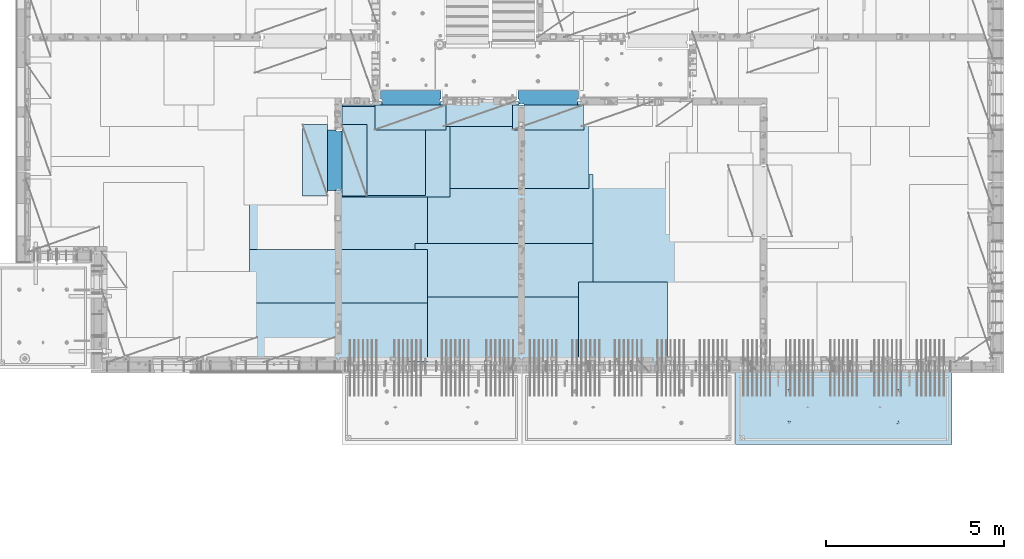
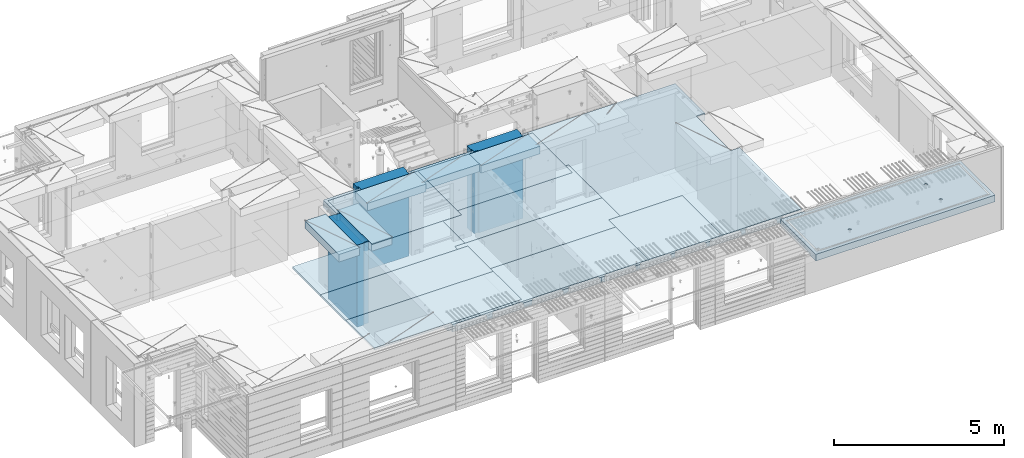
# One storey, part 204 of 350: 18 plates, 3 slabs, 19 elements without a shape of their own.
"""IFC2X3 building model written with IfcOpenShell, lengths in millimetres."""

from ifc_helpers import new_model, si_unit, frame, origin_with_axes, place, context, subcontext, project, spatial, faceted_brep, material, type_object, element, aggregate, save


model = new_model("IFC2X3")

# Units and contexts
model_context = context("Model", 3, precision=1e-05, world=origin_with_axes())
body_context = subcontext(model_context, "Body", "Model", "MODEL_VIEW")
ifc_project = project(units=[si_unit("LENGTHUNIT", "METRE", prefix="MILLI"), si_unit("AREAUNIT", "SQUARE_METRE"), si_unit("VOLUMEUNIT", "CUBIC_METRE"), si_unit("MASSUNIT", "GRAM", prefix="KILO"), si_unit("TIMEUNIT", "SECOND"), si_unit("PLANEANGLEUNIT", "RADIAN"), si_unit("SOLIDANGLEUNIT", "STERADIAN"), si_unit("THERMODYNAMICTEMPERATUREUNIT", "DEGREE_CELSIUS"), si_unit("LUMINOUSINTENSITYUNIT", "LUMEN")], contexts=[model_context])

# Site, building, storey
site_placement = place(None, origin_with_axes())
site = spatial("IfcSite", under=ifc_project, at=site_placement, CompositionType="ELEMENT")
building_placement = place(site_placement, origin_with_axes())
building = spatial("IfcBuilding", under=site, at=building_placement, CompositionType="ELEMENT")
storey_placement = place(building_placement, origin_with_axes())
storey = spatial("IfcBuildingStorey", under=building, at=storey_placement, Name="2", CompositionType="ELEMENT", Elevation=0.0)

# Assembly, slab
assembly_1_placement = place(storey_placement, origin_with_axes())
assembly_1 = element("IfcElementAssembly", 1, at=assembly_1_placement, inside=storey, AssemblyPlace="NOTDEFINED", PredefinedType="REINFORCEMENT_UNIT")
ifc_material_1 = material(Name="CONCRETE/C30/37")
slab_type_1 = type_object("IfcSlabType", PredefinedType="NOTDEFINED")
slab_1_placement = place(assembly_1_placement, frame((21810.0, 7750.0, 87595.0), z_axis=(0.0, 1.0, 0.0), x_axis=(1.0, 0.0, 0.0)))
slab_1 = element("IfcSlab", 2, at=slab_1_placement, type_object=slab_type_1, material=ifc_material_1, PredefinedType="FLOOR", context=body_context, shape_type="Brep", body=[
    faceted_brep([(6500.0, -135.0, 5637.99963378906), (6500.0, 135.0, 5637.99963378906), (6500.0, 135.0, 5680.0), (6500.0, -135.0, 5680.0), (6800.0, -135.0, 5680.0), (6800.0, 135.0, 5680.0), (6800.0, -135.0, 3637.99963378906), (6800.0, 135.0, 3637.99963378906), (6500.0, 135.0, 3637.99963378906), (6500.0, -135.0, 3637.99963378906), (6800.0, -135.0, 0.0), (6800.0, 135.0, 0.0), (1.81898940354586e-12, -135.0, 1.81898940354586e-12), (1.81898940354586e-12, 135.0, 1.81898940354586e-12), (0.0, -135.0, 7330.0), (0.0, 135.0, 7330.0), (1569.99914550782, -135.0, 7330.0), (1569.99914550782, 135.0, 7330.0), (1569.99914550782, -135.0, 7430.0), (1569.99914550782, 135.0, 7430.0), (6800.0, -135.0, 7430.0), (6800.0, 135.0, 7430.0), (6500.0, 135.0, 3780.0), (6500.0, -135.0, 3780.0)], [[[0, 1, 2, 3]], [[4, 3, 2, 5]], [[6, 7, 8, 9]], [[10, 11, 7, 6]], [[10, 12, 13, 11]], [[12, 14, 15, 13]], [[16, 17, 15, 14]], [[18, 19, 17, 16]], [[20, 21, 19, 18]], [[21, 20, 4, 5]], [[1, 22, 8, 7, 11, 13, 15, 17, 19, 21, 5, 2]], [[23, 9, 8, 22, 1, 0]], [[20, 18, 16, 14, 12, 10, 6, 9, 23, 0, 3, 4]]]),
])

assembly_2_placement = place(storey_placement, origin_with_axes())
assembly_2 = element("IfcElementAssembly", 3, at=assembly_2_placement, inside=storey, AssemblyPlace="NOTDEFINED", PredefinedType="REINFORCEMENT_UNIT")
ifc_material_2 = material(Name="CONCRETE/C35/45")
slab_type_2 = type_object("IfcSlabType", PredefinedType="NOTDEFINED")
slab_2_placement = place(assembly_2_placement, frame((33909.9998568133, 7629.99655735226, 87590.0), z_axis=(-1.11800000013248e-06, -0.999999999999375, 0.0), x_axis=(-0.999999999999093, 1.34699999998405e-06, 0.0)))
slab_2 = element("IfcSlab", 4, at=slab_2_placement, type_object=slab_type_2, material=ifc_material_2, PredefinedType="FLOOR", context=body_context, shape_type="Brep", body=[
    faceted_brep([(4605.44993885855, -113.0, 552.448239707288), (4619.38834372919, -113.0, 559.550231553701), (4630.44991833371, -113.0, 570.61183115741), (4637.55187867931, -113.0, 584.55025207851), (4639.99903540509, -113.0, 600.001104562554), (4637.55184376039, -113.0, 615.451951515985), (4630.44985191398, -113.0, 629.39035638662), (4619.38825231027, -113.0, 640.451930991143), (4605.44983138917, -113.0, 647.553891336743), (4589.99897890513, -113.0, 650.001048062522), (4574.54813195169, -113.0, 647.553856417822), (4560.60972708106, -113.0, 640.451864571409), (4549.54815247653, -113.0, 629.390264967699), (4542.44619213093, -113.0, 615.451844046599), (4539.99903540516, -113.0, 600.000991562554), (4542.44622704986, -113.0, 584.550144609124), (4549.54821889627, -113.0, 570.61173973849), (4560.60981849998, -113.0, 559.550165133966), (4574.54823942108, -113.0, 552.448204788368), (4589.99909190512, -113.0, 550.001048062586), (4548.90468317908, -120.0, 570.144182560607), (4541.68970509875, -120.0, 584.304334781456), (4560.14226277649, -120.0, 558.906628360102), (4574.30243130315, -120.0, 551.691682281732), (4589.99909280399, -120.0, 549.205593517132), (4605.69574868622, -120.0, 551.691717756181), (4619.85590090707, -120.0, 558.906695836513), (4631.09345510757, -120.0, 570.14427543392), (4638.30840118594, -120.0, 584.304443960583), (4640.79448995055, -120.0, 600.001105461418), (4638.30836571149, -120.0, 615.697761343653), (4631.09338763116, -120.0, 629.857913564502), (4619.85580803376, -120.0, 641.095467765007), (4605.6956395071, -120.0, 648.310413843377), (4589.99897800626, -120.0, 650.796502607977), (4574.30232212402, -120.0, 648.310378368928), (4560.14216990317, -120.0, 641.095400288596), (4548.90461570267, -120.0, 629.85782069119), (4541.6896696243, -120.0, 615.697652164527), (4539.2035808597, -120.0, 600.000990663691), (0.000819232023786753, -120.0, 2085.00366210938), (6090.0009765625, -120.0, 2085.00366210938), (6090.0009765625, 120.0, 2085.00366210938), (0.000819232023786753, 120.0, 2085.00366210938), (6090.0, -120.0, 1.39971234602854e-09), (6090.0, 120.0, 1.39971234602854e-09), (-7.27595761418343e-12, -120.0, -9.09494701772928e-13), (-7.27595761418343e-12, 120.0, -9.09494701772928e-13), (1515.44893888152, -108.0, 1437.45474794476), (1529.38734375216, -108.0, 1444.55673979117), (1540.44891835668, -108.0, 1455.61833939488), (1547.55087870228, -108.0, 1469.55676031598), (1549.99803542806, -108.0, 1485.00761280002), (1547.55084378336, -108.0, 1500.45845975345), (1540.44885193695, -108.0, 1514.39686462409), (1529.38725233324, -108.0, 1525.45843922861), (1515.44883141214, -108.0, 1532.56039957421), (1499.99797892809, -108.0, 1535.00755629999), (1484.54713197466, -108.0, 1532.56036465529), (1470.60872710403, -108.0, 1525.45837280888), (1459.5471524995, -108.0, 1514.39677320517), (1452.44519215391, -108.0, 1500.45835228407), (1449.99803542813, -108.0, 1485.00749980002), (1452.44522707283, -108.0, 1469.55665284659), (1459.54721891924, -108.0, 1455.61824797596), (1470.60881852295, -108.0, 1444.55667337144), (1484.54723944405, -108.0, 1437.45471302584), (1499.99809192809, -108.0, 1435.00755630005), (1451.1483322995, -120.0, 1469.13526457059), (1448.63439906449, -120.0, 1485.00749825911), (1458.44401483263, -120.0, 1454.8167213853), (1469.80729442553, -120.0, 1443.45346747338), (1484.12585409903, -120.0, 1436.15781730018), (1499.998093469, -120.0, 1433.64391993642), (1515.87032715753, -120.0, 1436.15785317143), (1530.18887034281, -120.0, 1443.45353570456), (1541.55212425473, -120.0, 1454.81681529746), (1548.84777442794, -120.0, 1469.13537497096), (1551.3616717917, -120.0, 1485.00761434093), (1548.84773855669, -120.0, 1500.87984802946), (1541.55205602355, -120.0, 1515.19839121474), (1530.18877643065, -120.0, 1526.56164512666), (1515.87021675716, -120.0, 1533.85729529987), (1499.99797738718, -120.0, 1536.37119266363), (1484.12574369866, -120.0, 1533.85725942862), (1469.80720051337, -120.0, 1526.56157689548), (1458.44394660145, -120.0, 1515.19829730258), (1451.14829642824, -120.0, 1500.87973762909), (1515.44993893152, -113.0, 552.45474794532), (1529.38834380215, -113.0, 559.556739791733), (1540.44991840668, -113.0, 570.618339395443), (1547.55187875228, -113.0, 584.556760316543), (1549.99903547806, -113.0, 600.007612800588), (1547.55184383336, -113.0, 615.458459754018), (1540.44985198694, -113.0, 629.396864624653), (1529.38825238323, -113.0, 640.458439229175), (1515.44983146213, -113.0, 647.560399574775), (1499.99897897809, -113.0, 650.007556300556), (1484.54813202466, -113.0, 647.560364655855), (1470.60972715402, -113.0, 640.458372809442), (1459.5481525495, -113.0, 629.396773205733), (1452.4461922039, -113.0, 615.458352284632), (1449.99903547812, -113.0, 600.007499800588), (1452.44622712283, -113.0, 584.556652847157), (1459.54821896923, -113.0, 570.618247976523), (1470.60981857295, -113.0, 559.556673372), (1484.54823949404, -113.0, 552.4547130264), (1499.99909197809, -113.0, 550.007556300619), (1451.68970517172, -120.0, 584.310843019489), (1449.20358093267, -120.0, 600.007498901724), (1458.90468325205, -120.0, 570.15069079864), (1470.14226284945, -120.0, 558.913136598135), (1484.30243137612, -120.0, 551.698190519764), (1499.99909287695, -120.0, 549.212101755165), (1515.69574875919, -120.0, 551.698225994213), (1529.85590098004, -120.0, 558.913204074546), (1541.09345518054, -120.0, 570.150783671952), (1548.30840125891, -120.0, 584.310952198615), (1550.79449002351, -120.0, 600.007613699451), (1548.30836578447, -120.0, 615.704269581685), (1541.09338770413, -120.0, 629.864421802535), (1529.85580810672, -120.0, 641.10197600304), (1515.69563958006, -120.0, 648.31692208141), (1499.99897807923, -120.0, 650.803010846011), (1484.30232219699, -120.0, 648.316886606961), (1470.14216997614, -120.0, 641.101908526629), (1458.90461577564, -120.0, 629.864328929222), (1451.68966969727, -120.0, 615.704160402559), (4605.44893880856, -108.0, 1437.44823970672), (4619.38734367919, -108.0, 1444.55023155314), (4630.44891828372, -108.0, 1455.61183115685), (4637.55087862931, -108.0, 1469.55025207795), (4639.99803535509, -108.0, 1485.00110456199), (4637.55084371039, -108.0, 1500.45195151542), (4630.44885186398, -108.0, 1514.39035638605), (4619.38725226027, -108.0, 1525.45193099058), (4605.44883133917, -108.0, 1532.55389133618), (4589.99797885512, -108.0, 1535.00104806196), (4574.54713190169, -108.0, 1532.55385641726), (4560.60872703106, -108.0, 1525.45186457084), (4549.54715242653, -108.0, 1514.39026496713), (4542.44519208094, -108.0, 1500.45184404603), (4539.99803535516, -108.0, 1485.00099156199), (4542.44522699986, -108.0, 1469.55014460856), (4549.54721884627, -108.0, 1455.61173973792), (4560.60881844998, -108.0, 1444.5501651334), (4574.54723937108, -108.0, 1437.4482047878), (4589.99809185513, -108.0, 1435.00104806202), (4541.14833222653, -120.0, 1469.12875633256), (4538.63439899152, -120.0, 1485.00099002108), (4548.44401475967, -120.0, 1454.81021314727), (4559.80729435257, -120.0, 1443.44695923535), (4574.12585402606, -120.0, 1436.15130906214), (4589.99809339604, -120.0, 1433.63741169839), (4605.87032708456, -120.0, 1436.1513449334), (4620.18887026985, -120.0, 1443.44702746653), (4631.55212418177, -120.0, 1454.81030705943), (4638.84777435497, -120.0, 1469.12886673293), (4641.36167171873, -120.0, 1485.0011061029), (4638.84773848372, -120.0, 1500.87333979142), (4631.55205595059, -120.0, 1515.19188297671), (4620.18877635769, -120.0, 1526.55513688863), (4605.87021668419, -120.0, 1533.85078706184), (4589.99797731422, -120.0, 1536.36468442559), (4574.12574362569, -120.0, 1533.85075119058), (4559.80720044041, -120.0, 1526.55506865745), (4548.44394652849, -120.0, 1515.19178906455), (4541.14829635528, -120.0, 1500.87322939105)], [[[0, 1, 2, 3, 4, 5, 6, 7, 8, 9, 10, 11, 12, 13, 14, 15, 16, 17, 18, 19]], [[20, 16, 15, 21]], [[22, 17, 16, 20]], [[23, 18, 17, 22]], [[24, 19, 18, 23]], [[25, 0, 19, 24]], [[26, 1, 0, 25]], [[27, 2, 1, 26]], [[28, 3, 2, 27]], [[29, 4, 3, 28]], [[30, 5, 4, 29]], [[31, 6, 5, 30]], [[32, 7, 6, 31]], [[33, 8, 7, 32]], [[34, 9, 8, 33]], [[35, 10, 9, 34]], [[36, 11, 10, 35]], [[37, 12, 11, 36]], [[38, 13, 12, 37]], [[39, 14, 13, 38]], [[21, 15, 14, 39]], [[40, 41, 42, 43]], [[41, 44, 45, 42]], [[44, 46, 47, 45]], [[42, 45, 47, 43]], [[46, 40, 43, 47]], [[48, 49, 50, 51, 52, 53, 54, 55, 56, 57, 58, 59, 60, 61, 62, 63, 64, 65, 66, 67]], [[68, 63, 62, 69]], [[70, 64, 63, 68]], [[71, 65, 64, 70]], [[72, 66, 65, 71]], [[73, 67, 66, 72]], [[74, 48, 67, 73]], [[75, 49, 48, 74]], [[76, 50, 49, 75]], [[77, 51, 50, 76]], [[78, 52, 51, 77]], [[79, 53, 52, 78]], [[80, 54, 53, 79]], [[81, 55, 54, 80]], [[82, 56, 55, 81]], [[83, 57, 56, 82]], [[84, 58, 57, 83]], [[85, 59, 58, 84]], [[86, 60, 59, 85]], [[87, 61, 60, 86]], [[69, 62, 61, 87]], [[88, 89, 90, 91, 92, 93, 94, 95, 96, 97, 98, 99, 100, 101, 102, 103, 104, 105, 106, 107]], [[108, 103, 102, 109]], [[110, 104, 103, 108]], [[111, 105, 104, 110]], [[112, 106, 105, 111]], [[113, 107, 106, 112]], [[114, 88, 107, 113]], [[115, 89, 88, 114]], [[116, 90, 89, 115]], [[117, 91, 90, 116]], [[118, 92, 91, 117]], [[119, 93, 92, 118]], [[120, 94, 93, 119]], [[121, 95, 94, 120]], [[122, 96, 95, 121]], [[123, 97, 96, 122]], [[124, 98, 97, 123]], [[125, 99, 98, 124]], [[126, 100, 99, 125]], [[127, 101, 100, 126]], [[109, 102, 101, 127]], [[128, 129, 130, 131, 132, 133, 134, 135, 136, 137, 138, 139, 140, 141, 142, 143, 144, 145, 146, 147]], [[148, 143, 142, 149]], [[150, 144, 143, 148]], [[151, 145, 144, 150]], [[152, 146, 145, 151]], [[153, 147, 146, 152]], [[154, 128, 147, 153]], [[155, 129, 128, 154]], [[156, 130, 129, 155]], [[157, 131, 130, 156]], [[158, 132, 131, 157]], [[159, 133, 132, 158]], [[160, 134, 133, 159]], [[161, 135, 134, 160]], [[162, 136, 135, 161]], [[163, 137, 136, 162]], [[164, 138, 137, 163]], [[165, 139, 138, 164]], [[166, 140, 139, 165]], [[167, 141, 140, 166]], [[149, 142, 141, 167]], [[44, 41, 40, 46], [37, 36, 35, 34, 33, 32, 31, 30, 29, 28, 27, 26, 25, 24, 23, 22, 20, 21, 39, 38], [166, 165, 164, 163, 162, 161, 160, 159, 158, 157, 156, 155, 154, 153, 152, 151, 150, 148, 149, 167], [126, 125, 124, 123, 122, 121, 120, 119, 118, 117, 116, 115, 114, 113, 112, 111, 110, 108, 109, 127], [86, 85, 84, 83, 82, 81, 80, 79, 78, 77, 76, 75, 74, 73, 72, 71, 70, 68, 69, 87]]]),
])
aggregate(assembly_2, [slab_2])

# Assembly, plate
assembly_3_placement = place(storey_placement, origin_with_axes())
assembly_3 = element("IfcElementAssembly", 5, at=assembly_3_placement, inside=storey, Name="Steel Assembly", AssemblyPlace="NOTDEFINED", PredefinedType="NOTDEFINED")
ifc_material_3 = material()
plate_type_1 = type_object("IfcPlateType", PredefinedType="NOTDEFINED")
plate_1_placement = place(assembly_3_placement, frame((25910.0, 7750.0, 87695.1), z_axis=(-1.0, 3.00000001838171e-08, 0.0), x_axis=(0.0, 1.0, 0.0)))
plate_1 = element("IfcPlate", 6, at=plate_1_placement, type_object=plate_type_1, material=ifc_material_3, Name="1/2", context=body_context, shape_type="Brep", body=[
    faceted_brep([(0.0, -35.0, 0.0), (0.0, -35.0, 2500.0), (0.0, 35.0, 2500.0), (0.0, 35.0, 0.0), (2349.99951171875, -35.0, 2500.0), (2349.99951171875, 35.0, 2500.0), (2350.0, -35.0, 0.0), (2350.0, 35.0, 0.0)], [[[0, 1, 2, 3]], [[1, 4, 5, 2]], [[4, 6, 7, 5]], [[6, 0, 3, 7]], [[5, 7, 3, 2]], [[6, 4, 1, 0]]]),
])
aggregate(assembly_3, [plate_1])

assembly_4_placement = place(storey_placement, origin_with_axes())
assembly_4 = element("IfcElementAssembly", 7, at=assembly_4_placement, inside=storey, Name="Steel Assembly", AssemblyPlace="NOTDEFINED", PredefinedType="NOTDEFINED")
plate_2_placement = place(assembly_4_placement, frame((16759.9995320312, 12530.0000289158, 87695.1), z_axis=(0.0, 1.0, 0.0), x_axis=(1.0, 0.0, 0.0)))
plate_2 = element("IfcPlate", 8, at=plate_2_placement, type_object=plate_type_1, material=ifc_material_3, Name="1/2", context=body_context, shape_type="Brep", body=[
    faceted_brep([(0.0, -35.0, 0.0), (0.0, -35.0, 2500.0), (0.0, 35.0, 2500.0), (0.0, 35.0, 0.0), (2349.99951171875, -35.0, 2500.0), (2349.99951171875, 35.0, 2500.0), (2350.0, -35.0, 0.0), (2350.0, 35.0, 0.0)], [[[0, 1, 2, 3]], [[1, 4, 5, 2]], [[4, 6, 7, 5]], [[6, 0, 3, 7]], [[5, 7, 3, 2]], [[6, 4, 1, 0]]]),
])
aggregate(assembly_4, [plate_2])

assembly_5_placement = place(storey_placement, origin_with_axes())
assembly_5 = element("IfcElementAssembly", 9, at=assembly_5_placement, inside=storey, Name="Steel Assembly", AssemblyPlace="NOTDEFINED", PredefinedType="NOTDEFINED")
plate_3_placement = place(assembly_5_placement, frame((23810.0, 10780.0, 87695.1), z_axis=(-1.0, 3.00000001838171e-08, 0.0), x_axis=(0.0, 1.0, 0.0)))
plate_3 = element("IfcPlate", 10, at=plate_3_placement, type_object=plate_type_1, material=ifc_material_3, context=body_context, shape_type="Brep", body=[
    faceted_brep([(0.0, -35.0, 0.0), (0.0, -35.0, 5000.0), (0.0, 35.0, 5000.0), (0.0, 35.0, 0.0), (2349.99951171875, -35.0, 5000.0), (2349.99951171875, 35.0, 5000.0), (2350.0, -35.0, 0.0), (2350.0, 35.0, 0.0)], [[[0, 1, 2, 3]], [[1, 4, 5, 2]], [[4, 6, 7, 5]], [[6, 0, 3, 7]], [[5, 7, 3, 2]], [[6, 4, 1, 0]]]),
])
aggregate(assembly_5, [plate_3])

assembly_6_placement = place(storey_placement, origin_with_axes())
assembly_6 = element("IfcElementAssembly", 11, at=assembly_6_placement, inside=storey, Name="Steel Assembly", AssemblyPlace="NOTDEFINED", PredefinedType="NOTDEFINED")
plate_4_placement = place(assembly_6_placement, frame((23710.0, 12730.0, 87695.1), z_axis=(-1.0, 3.00000001838171e-08, 0.0), x_axis=(0.0, 1.0, 0.0)))
plate_4 = element("IfcPlate", 12, at=plate_4_placement, type_object=plate_type_1, material=ifc_material_3, context=body_context, shape_type="Brep", body=[
    faceted_brep([(0.0, -35.0, 0.0), (0.0, -35.0, 5000.0), (0.0, 35.0, 5000.0), (0.0, 35.0, 0.0), (2349.99951171875, -35.0, 5000.0), (2349.99951171875, 35.0, 5000.0), (2350.0, -35.0, 0.0), (2350.0, 35.0, 0.0)], [[[0, 1, 2, 3]], [[1, 4, 5, 2]], [[4, 6, 7, 5]], [[6, 0, 3, 7]], [[5, 7, 3, 2]], [[6, 4, 1, 0]]]),
])
aggregate(assembly_6, [plate_4])

assembly_7_placement = place(storey_placement, origin_with_axes())
assembly_7 = element("IfcElementAssembly", 13, at=assembly_7_placement, inside=storey, Name="Steel Assembly", AssemblyPlace="NOTDEFINED", PredefinedType="NOTDEFINED")
plate_5_placement = place(assembly_7_placement, frame((23810.0, 7750.0, 87695.1), z_axis=(-1.0, 3.00000001838171e-08, 0.0), x_axis=(0.0, 1.0, 0.0)))
plate_5 = element("IfcPlate", 14, at=plate_5_placement, type_object=plate_type_1, material=ifc_material_3, context=body_context, shape_type="Brep", body=[
    faceted_brep([(0.0, -35.0, 0.0), (0.0, -35.0, 5000.0), (0.0, 35.0, 5000.0), (0.0, 35.0, 0.0), (2349.99951171875, -35.0, 5000.0), (2349.99951171875, 35.0, 5000.0), (2350.0, -35.0, 0.0), (2350.0, 35.0, 0.0)], [[[0, 1, 2, 3]], [[1, 4, 5, 2]], [[4, 6, 7, 5]], [[6, 0, 3, 7]], [[5, 7, 3, 2]], [[6, 4, 1, 0]]]),
])
aggregate(assembly_7, [plate_5])

assembly_8_placement = place(storey_placement, origin_with_axes())
assembly_8 = element("IfcElementAssembly", 15, at=assembly_8_placement, inside=storey, Name="Steel Assembly", AssemblyPlace="NOTDEFINED", PredefinedType="NOTDEFINED")
plate_6_placement = place(assembly_8_placement, frame((19160.0, 10325.0, 87695.1), z_axis=(-1.0, 3.00000001838171e-08, 0.0), x_axis=(0.0, 1.0, 0.0)))
plate_6 = element("IfcPlate", 16, at=plate_6_placement, type_object=plate_type_1, material=ifc_material_3, context=body_context, shape_type="Brep", body=[
    faceted_brep([(0.0, -35.0, 0.0), (0.0, -35.0, 5000.0), (0.0, 35.0, 5000.0), (0.0, 35.0, 0.0), (2349.99951171875, -35.0, 5000.0), (2349.99951171875, 35.0, 5000.0), (2350.0, -35.0, 0.0), (2350.0, 35.0, 0.0)], [[[0, 1, 2, 3]], [[1, 4, 5, 2]], [[4, 6, 7, 5]], [[6, 0, 3, 7]], [[5, 7, 3, 2]], [[6, 4, 1, 0]]]),
])
aggregate(assembly_8, [plate_6])

assembly_9_placement = place(storey_placement, origin_with_axes())
assembly_9 = element("IfcElementAssembly", 17, at=assembly_9_placement, inside=storey, Name="Steel Assembly", AssemblyPlace="NOTDEFINED", PredefinedType="NOTDEFINED")
plate_7_placement = place(assembly_9_placement, frame((19160.0, 7850.0, 87695.1), z_axis=(-1.0, 3.00000001838171e-08, 0.0), x_axis=(0.0, 1.0, 0.0)))
plate_7 = element("IfcPlate", 18, at=plate_7_placement, type_object=plate_type_1, material=ifc_material_3, context=body_context, shape_type="Brep", body=[
    faceted_brep([(0.0, -35.0, 0.0), (0.0, -35.0, 5000.0), (0.0, 35.0, 5000.0), (0.0, 35.0, 0.0), (2349.99951171875, -35.0, 5000.0), (2349.99951171875, 35.0, 5000.0), (2350.0, -35.0, 0.0), (2350.0, 35.0, 0.0)], [[[0, 1, 2, 3]], [[1, 4, 5, 2]], [[4, 6, 7, 5]], [[6, 0, 3, 7]], [[5, 7, 3, 2]], [[6, 4, 1, 0]]]),
])
aggregate(assembly_9, [plate_7])

assembly_10_placement = place(storey_placement, origin_with_axes())
assembly_10 = element("IfcElementAssembly", 19, at=assembly_10_placement, inside=storey, Name="Steel Assembly", AssemblyPlace="NOTDEFINED", PredefinedType="NOTDEFINED")
plate_type_2 = type_object("IfcPlateType", PredefinedType="NOTDEFINED")
plate_8_placement = place(assembly_10_placement, frame((18810.0, 11180.0000122641, 87695.1000003815), z_axis=(1.0, 0.0, 0.0), x_axis=(0.0, -1.0, 0.0)))
plate_8 = element("IfcPlate", 20, at=plate_8_placement, type_object=plate_type_2, material=ifc_material_3, context=body_context, shape_type="Brep", body=[
    faceted_brep([(0.0, -35.0, 0.0), (0.0, -35.0, 5000.0), (0.0, 35.0, 5000.0), (0.0, 35.0, 0.0), (1499.99951171875, -35.0, 5000.0), (1499.99951171875, 35.0, 5000.0), (1500.0, -35.0, 0.0), (1500.0, 35.0, 0.0)], [[[0, 1, 2, 3]], [[1, 4, 5, 2]], [[4, 6, 7, 5]], [[6, 0, 3, 7]], [[5, 7, 3, 2]], [[6, 4, 1, 0]]]),
])
aggregate(assembly_10, [plate_8])

assembly_11_placement = place(storey_placement, origin_with_axes())
assembly_11 = element("IfcElementAssembly", 21, at=assembly_11_placement, inside=storey, Name="Steel Assembly", AssemblyPlace="NOTDEFINED", PredefinedType="NOTDEFINED")
plate_9_placement = place(assembly_11_placement, frame((14160.0, 11015.0000122641, 87695.1000003815), z_axis=(1.0, 0.0, 0.0), x_axis=(0.0, -1.0, 0.0)))
plate_9 = element("IfcPlate", 22, at=plate_9_placement, type_object=plate_type_2, material=ifc_material_3, context=body_context, shape_type="Brep", body=[
    faceted_brep([(0.0, -35.0, 0.0), (0.0, -35.0, 5000.0), (0.0, 35.0, 5000.0), (0.0, 35.0, 0.0), (1499.99951171875, -35.0, 5000.0), (1499.99951171875, 35.0, 5000.0), (1500.0, -35.0, 0.0), (1500.0, 35.0, 0.0)], [[[0, 1, 2, 3]], [[1, 4, 5, 2]], [[4, 6, 7, 5]], [[6, 0, 3, 7]], [[5, 7, 3, 2]], [[6, 4, 1, 0]]]),
])
aggregate(assembly_11, [plate_9])

assembly_12_placement = place(storey_placement, origin_with_axes())
assembly_12 = element("IfcElementAssembly", 23, at=assembly_12_placement, inside=storey, Name="Steel Assembly", AssemblyPlace="NOTDEFINED", PredefinedType="NOTDEFINED")
plate_type_3 = type_object("IfcPlateType", PredefinedType="NOTDEFINED")
plate_10_placement = place(assembly_12_placement, frame((16759.9998779297, 14525.0, 87595.3), z_axis=(1.0, 0.0, 0.0), x_axis=(0.0, -1.0, 0.0)))
plate_10 = element("IfcPlate", 24, at=plate_10_placement, type_object=plate_type_3, material=ifc_material_3, Name="RE1", context=body_context, shape_type="Brep", body=[
    faceted_brep([(1.81898940354586e-12, -135.0, 1.81898940354586e-12), (0.0, -135.0, 699.999999999996), (0.0, 135.0, 699.999999999996), (1.81898940354586e-12, 135.0, 1.81898940354586e-12), (1999.99951171875, -135.0, 699.999999999993), (1999.99951171875, 135.0, 699.999999999993), (2000.0, -135.0, -3.63797880709171e-12), (2000.0, 135.0, -3.63797880709171e-12)], [[[0, 1, 2, 3]], [[1, 4, 5, 2]], [[4, 6, 7, 5]], [[6, 0, 3, 7]], [[5, 7, 3, 2]], [[6, 4, 1, 0]]]),
])
aggregate(assembly_12, [plate_10])

assembly_13_placement = place(storey_placement, origin_with_axes())
assembly_13 = element("IfcElementAssembly", 25, at=assembly_13_placement, inside=storey, Name="Steel Assembly", AssemblyPlace="NOTDEFINED", PredefinedType="NOTDEFINED")
plate_11_placement = place(assembly_13_placement, frame((16359.7701220703, 12525.0, 87595.3), z_axis=(-1.0, 3.00000001838171e-08, 0.0), x_axis=(0.0, 1.0, 0.0)))
plate_11 = element("IfcPlate", 26, at=plate_11_placement, type_object=plate_type_3, material=ifc_material_3, Name="RE1", context=body_context, shape_type="Brep", body=[
    faceted_brep([(1.81898940354586e-12, -135.0, 1.81898940354586e-12), (0.0, -135.0, 699.999999999996), (0.0, 135.0, 699.999999999996), (1.81898940354586e-12, 135.0, 1.81898940354586e-12), (1999.99951171875, -135.0, 699.999999999993), (1999.99951171875, 135.0, 699.999999999993), (2000.0, -135.0, -3.63797880709171e-12), (2000.0, 135.0, -3.63797880709171e-12)], [[[0, 1, 2, 3]], [[1, 4, 5, 2]], [[4, 6, 7, 5]], [[6, 0, 3, 7]], [[5, 7, 3, 2]], [[6, 4, 1, 0]]]),
])
aggregate(assembly_13, [plate_11])

assembly_14_placement = place(storey_placement, origin_with_axes())
assembly_14 = element("IfcElementAssembly", 27, at=assembly_14_placement, inside=storey, Name="Steel Assembly", AssemblyPlace="NOTDEFINED", PredefinedType="NOTDEFINED")
plate_12_placement = place(assembly_14_placement, frame((21624.9991457614, 15179.9998963664, 87595.3), z_axis=(0.0, -1.0, 0.0), x_axis=(-1.0, 3.00000001838171e-08, 0.0)))
plate_12 = element("IfcPlate", 28, at=plate_12_placement, type_object=plate_type_3, material=ifc_material_3, Name="RE1", context=body_context, shape_type="Brep", body=[
    faceted_brep([(1.81898940354586e-12, -135.0, 1.81898940354586e-12), (0.0, -135.0, 699.999999999996), (0.0, 135.0, 699.999999999996), (1.81898940354586e-12, 135.0, 1.81898940354586e-12), (1999.99951171875, -135.0, 699.999999999993), (1999.99951171875, 135.0, 699.999999999993), (2000.0, -135.0, -3.63797880709171e-12), (2000.0, 135.0, -3.63797880709171e-12)], [[[0, 1, 2, 3]], [[1, 4, 5, 2]], [[4, 6, 7, 5]], [[6, 0, 3, 7]], [[5, 7, 3, 2]], [[6, 4, 1, 0]]]),
])
aggregate(assembly_14, [plate_12])

assembly_15_placement = place(storey_placement, origin_with_axes())
assembly_15 = element("IfcElementAssembly", 29, at=assembly_15_placement, inside=storey, Name="Steel Assembly", AssemblyPlace="NOTDEFINED", PredefinedType="NOTDEFINED")
plate_13_placement = place(assembly_15_placement, frame((23559.9991457614, 15079.9998963664, 87595.3), z_axis=(0.0, -1.0, 0.0), x_axis=(-1.0, 3.00000001838171e-08, 0.0)))
plate_13 = element("IfcPlate", 30, at=plate_13_placement, type_object=plate_type_3, material=ifc_material_3, Name="RE1", context=body_context, shape_type="Brep", body=[
    faceted_brep([(1.81898940354586e-12, -135.0, 1.81898940354586e-12), (0.0, -135.0, 699.999999999996), (0.0, 135.0, 699.999999999996), (1.81898940354586e-12, 135.0, 1.81898940354586e-12), (1999.99951171875, -135.0, 699.999999999993), (1999.99951171875, 135.0, 699.999999999993), (2000.0, -135.0, -3.63797880709171e-12), (2000.0, 135.0, -3.63797880709171e-12)], [[[0, 1, 2, 3]], [[1, 4, 5, 2]], [[4, 6, 7, 5]], [[6, 0, 3, 7]], [[5, 7, 3, 2]], [[6, 4, 1, 0]]]),
])
aggregate(assembly_15, [plate_13])

assembly_16_placement = place(storey_placement, origin_with_axes())
assembly_16 = element("IfcElementAssembly", 31, at=assembly_16_placement, inside=storey, Name="Steel Assembly", AssemblyPlace="NOTDEFINED", PredefinedType="NOTDEFINED")
plate_14_placement = place(assembly_16_placement, frame((19689.9991457614, 15079.9998963664, 87595.3), z_axis=(0.0, -1.0, 0.0), x_axis=(-1.0, 3.00000001838171e-08, 0.0)))
plate_14 = element("IfcPlate", 32, at=plate_14_placement, type_object=plate_type_3, material=ifc_material_3, Name="RE1", context=body_context, shape_type="Brep", body=[
    faceted_brep([(1.81898940354586e-12, -135.0, 1.81898940354586e-12), (0.0, -135.0, 699.999999999996), (0.0, 135.0, 699.999999999996), (1.81898940354586e-12, 135.0, 1.81898940354586e-12), (1999.99951171875, -135.0, 699.999999999993), (1999.99951171875, 135.0, 699.999999999993), (2000.0, -135.0, -3.63797880709171e-12), (2000.0, 135.0, -3.63797880709171e-12)], [[[0, 1, 2, 3]], [[1, 4, 5, 2]], [[4, 6, 7, 5]], [[6, 0, 3, 7]], [[5, 7, 3, 2]], [[6, 4, 1, 0]]]),
])
aggregate(assembly_16, [plate_14])

# Plate
plate_type_4 = type_object("IfcPlateType", PredefinedType="NOTDEFINED")
plate_15_placement = place(assembly_1_placement, frame((16760.0002457424, 12487.9997681111, 87725.45), z_axis=(0.0, 1.0, 0.0), x_axis=(1.0, 0.0, 0.0)))
plate_15 = element("IfcPlate", 33, at=plate_15_placement, type_object=plate_type_4, material=ifc_material_3, context=body_context, shape_type="Brep", body=[
    faceted_brep([(0.0, -5.0, 0.0), (0.0, -5.0, 2592.0), (0.0, 5.0, 2592.0), (0.0, 5.0, 0.0), (3041.99975585938, -5.0, 2592.0), (3041.99975585938, 5.0, 2592.0), (3041.99975585938, -5.0, 0.0), (3041.99975585938, 5.0, 0.0)], [[[0, 1, 2, 3]], [[1, 4, 5, 2]], [[4, 6, 7, 5]], [[6, 0, 3, 7]], [[5, 7, 3, 2]], [[6, 4, 1, 0]]]),
])

# Slab
slab_type_3 = type_object("IfcSlabType", PredefinedType="NOTDEFINED")
slab_3_placement = place(assembly_1_placement, frame((21810.0, 15180.0, 87595.0), z_axis=(0.0, -1.0, 0.0), x_axis=(-1.0, 3.00000001838171e-08, 0.0)))
slab_3 = element("IfcSlab", 34, at=slab_3_placement, type_object=slab_type_3, material=ifc_material_1, PredefinedType="FLOOR", context=body_context, shape_type="Brep", body=[
    faceted_brep([(2300.00087620694, -135.0, -2.78342304227408e-06), (2300.00087620694, 135.0, 0.0), (2300.00087620694, 135.0, 100.000233727807), (2300.00087620694, -135.0, 100.000233727807), (3920.000509996, 135.000000000015, 100.000233727807), (3920.000509996, -135.0, 100.000233727807), (3920.00085449219, -135.0, 0.0), (3920.00085449219, 135.0, 0.0), (5150.0, 135.0, 0.0), (5150.0, -135.0, 0.0), (5150.0, 135.0, 804.999923541527), (5150.0, -135.0, 804.999923541527), (5049.99975425761, 135.0, 804.999923541527), (5049.99975425761, -135.0, 804.999923541527), (5049.99975425761, 135.0, 2504.99992354153), (5049.99975425761, -135.0, 2504.99992354153), (5150.0, 135.0, 2504.99992354153), (5150.0, -135.0, 2504.99992354153), (5150.0, 135.0, 7330.0), (5150.0, -135.0, 7330.0), (5055.0, -135.0, 7330.0), (5055.0, 135.0, 7330.0), (5055.0, -135.0, 7430.0), (5055.0, 135.0, 7430.0), (0.0, -135.0, 7430.0), (0.0, 135.0, 7430.0), (70.0000000000036, -135.0, -8.47121555125341e-08), (3.63797880709171e-12, -135.0, 100.0), (70.0000000000036, -135.000000000015, 100.0), (70.0000000000036, 135.0, 0.0), (70.0000000000036, 135.0, 100.0), (0.0, 135.0, 100.0)], [[[0, 1, 2, 3]], [[3, 2, 4, 5]], [[6, 5, 4, 7]], [[8, 9, 6, 7]], [[9, 8, 10, 11]], [[11, 10, 12, 13]], [[13, 12, 14, 15]], [[15, 14, 16, 17]], [[18, 19, 17, 16]], [[20, 19, 18, 21]], [[22, 20, 21, 23]], [[24, 22, 23, 25]], [[26, 0, 3, 5, 6, 9, 11, 13, 15, 17, 19, 20, 22, 24, 27, 28]], [[1, 0, 26, 29]], [[25, 23, 21, 18, 16, 14, 12, 10, 8, 7, 4, 2, 1, 29, 30, 31]], [[26, 28, 30, 29]], [[27, 31, 30, 28]], [[24, 25, 31, 27]]]),
])

aggregate(assembly_1, [plate_15, slab_3, slab_1])

# Assembly, plate
assembly_17_placement = place(storey_placement, origin_with_axes())
assembly_17 = element("IfcElementAssembly", 35, at=assembly_17_placement, inside=storey, Name="Steel Assembly", AssemblyPlace="NOTDEFINED", PredefinedType="NOTDEFINED")
ifc_material_4 = material()
plate_type_5 = type_object("IfcPlateType", PredefinedType="NOTDEFINED")
plate_16_placement = place(assembly_17_placement, frame((17840.0, 15080.0, 86255.6000003815), z_axis=(0.0, 1.0, 0.0), x_axis=(1.0, 0.0, 0.0)))
plate_16 = element("IfcPlate", 36, at=plate_16_placement, type_object=plate_type_5, material=ifc_material_4, context=body_context, shape_type="Brep", body=[
    faceted_brep([(49.9991463160914, -1475.0, 156.999999814216), (49.9991455078125, -1216.89999961853, 156.999999999998), (49.9994900039455, -1216.89999961853, -0.000233727812883444), (49.9994832763732, -1475.0, 0.0), (0.0, -1475.0, 170.000000230655), (-0.00085392879191204, -1216.89999961853, 170.000000368096), (0.0, -1475.0, 400.0), (1699.99914550781, -1475.0, 400.0), (1699.99914550781, 1475.0, 400.0), (0.0, 1475.0, 400.0), (1699.99914550781, -1475.0, 169.999999999998), (1699.99914550781, 1475.0, 169.999999999998), (1669.99914550781, 1475.0, 156.999999999998), (1669.99914550781, 1475.0, 3.63797880709171e-12), (49.9994900039455, 1475.0, 0.0), (49.9991455078125, 1475.0, 156.999999999998), (0.0, 1475.0, 170.000000368096), (1669.99914550781, -1475.0, 156.999999999998), (1669.99914550781, -1475.0, 3.63797880709171e-12)], [[[0, 1, 2, 3]], [[4, 5, 1, 0]], [[6, 7, 8, 9]], [[8, 7, 10, 11]], [[9, 8, 11, 12, 13, 14, 15, 16]], [[10, 17, 12, 11]], [[18, 13, 12, 17]], [[14, 13, 18, 3, 2]], [[14, 2, 1, 15]], [[15, 1, 5, 16]], [[6, 9, 16, 5, 4]], [[18, 17, 10, 7, 6, 4, 0, 3]]]),
])
aggregate(assembly_17, [plate_16])

assembly_18_placement = place(storey_placement, origin_with_axes())
assembly_18 = element("IfcElementAssembly", 37, at=assembly_18_placement, inside=storey, Name="Steel Assembly", AssemblyPlace="NOTDEFINED", PredefinedType="NOTDEFINED")
plate_17_placement = place(assembly_18_placement, frame((21710.0, 15080.0, 86255.6000003815), z_axis=(0.0, 1.0, 0.0), x_axis=(1.0, 0.0, 0.0)))
plate_17 = element("IfcPlate", 38, at=plate_17_placement, type_object=plate_type_5, material=ifc_material_4, context=body_context, shape_type="Brep", body=[
    faceted_brep([(30.0, -1475.0, 29.9998239177003), (30.0, 1475.0, 29.9998239177003), (157.0, 1475.0, 29.9998239177003), (157.0, -1475.0, 29.9998239177003), (169.999923697669, -1475.0, 0.0), (169.999923697669, 1475.0, 0.0), (0.0, -1475.0, 170.000000230655), (0.0, 1475.0, 170.000000368096), (30.0, 1475.0, 156.999999999998), (30.0, -1475.0, 156.999999999998), (0.0, -1475.0, 400.0), (0.0, 1475.0, 400.0), (1699.99914550781, -1475.0, 400.0), (1699.99914550781, 1475.0, 400.0), (1699.99914550781, -1475.0, 169.999999999998), (1699.99914550781, 1475.0, 169.999999999998), (1669.99914550781, -1475.0, 156.999999999998), (1669.99914550781, 1475.0, 156.999999999998), (1669.99914550781, -1475.0, 3.63797880709171e-12), (1669.99914550781, 1475.0, 3.63797880709171e-12)], [[[0, 1, 2, 3]], [[4, 3, 2, 5]], [[6, 7, 8, 9]], [[10, 11, 7, 6]], [[10, 12, 13, 11]], [[13, 12, 14, 15]], [[14, 16, 17, 15]], [[18, 19, 17, 16]], [[19, 18, 4, 5]], [[1, 8, 7, 11, 13, 15, 17, 19, 5, 2]], [[9, 8, 1, 0]], [[18, 16, 14, 12, 10, 6, 9, 0, 3, 4]]]),
])
aggregate(assembly_18, [plate_17])

assembly_19_placement = place(storey_placement, origin_with_axes())
assembly_19 = element("IfcElementAssembly", 39, at=assembly_19_placement, inside=storey, Name="Steel Assembly", AssemblyPlace="NOTDEFINED", PredefinedType="NOTDEFINED")
plate_18_placement = place(assembly_19_placement, frame((16760.0, 12675.0, 86255.6000003815), z_axis=(-0.999999990476206, -0.000138013000065496, 0.0), x_axis=(-0.000138013000066464, 0.999999990476206, 0.0)))
plate_18 = element("IfcPlate", 40, at=plate_18_placement, type_object=plate_type_5, material=ifc_material_4, context=body_context, shape_type="Brep", body=[
    faceted_brep([(0.0234607562470046, -1475.0, 169.989834633274), (0.0234607562470046, 1475.0, 169.989834633274), (30.0, 1475.0, 156.999999999998), (30.0, -1475.0, 156.999999999998), (29.9999998430139, -1475.0, 0.0), (29.9999998430139, 1475.0, 0.0), (0.0552374608814716, -1475.0, 400.234619140623), (1700.05529785156, -1475.0, 399.999999999998), (1700.05529785156, 1475.0, 399.999999999998), (0.0552374608814716, 1475.0, 400.234619140623), (1700.0235408123, -1475.0, 169.775517151291), (1700.0235408123, 1475.0, 169.775517151291), (1670.00014467176, -1475.0, 156.765378823566), (1670.00014467176, 1475.0, 156.765378823566), (1670.00014467148, -1475.0, 1.13504938781261e-09), (1670.00014467148, 1475.0, 1.13504938781261e-09)], [[[0, 1, 2, 3]], [[4, 3, 2, 5]], [[6, 7, 8, 9]], [[8, 7, 10, 11]], [[12, 13, 11, 10]], [[14, 15, 13, 12]], [[15, 14, 4, 5]], [[1, 9, 8, 11, 13, 15, 5, 2]], [[6, 9, 1, 0]], [[14, 12, 10, 7, 6, 0, 3, 4]]]),
])
aggregate(assembly_19, [plate_18])

save(model, "model.ifc")
